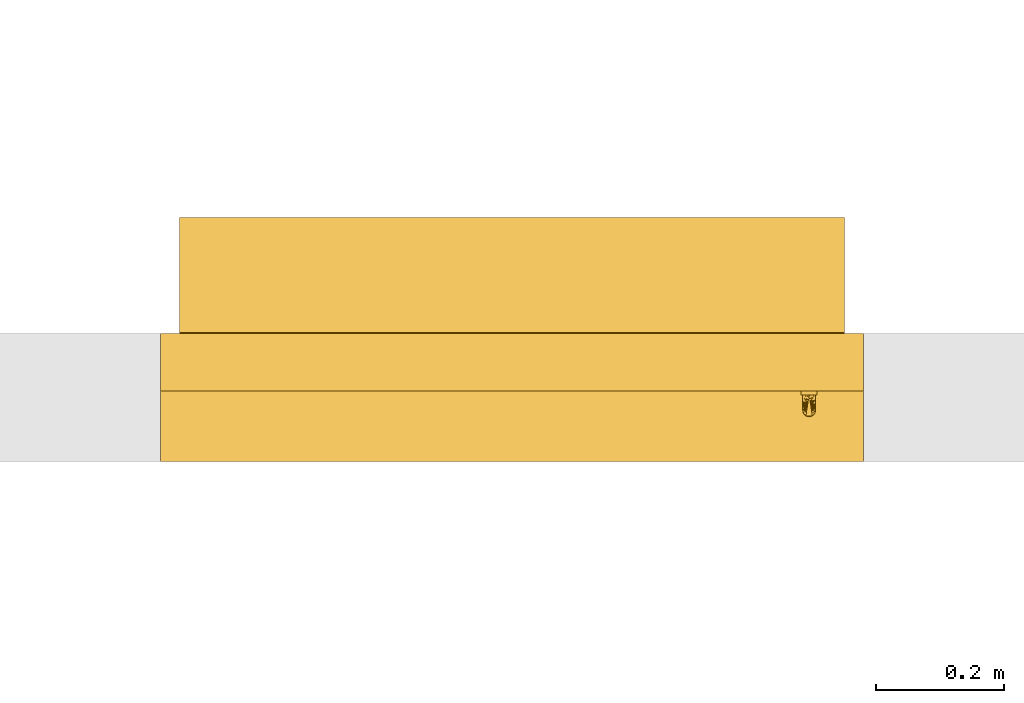
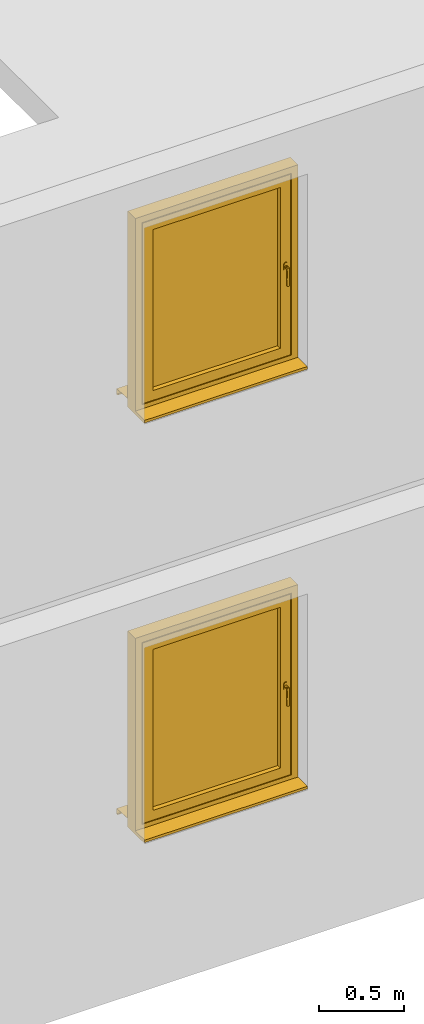
# Not in any storey, part 3 of 3: 2 windows.
"""IFC4 model written with IfcOpenShell, lengths in metres."""

from ifc_helpers import new_model, entity, si_unit, converted_unit, derived_unit, direction, frame, origin, place, context, subcontext, project, spatial, polygons, source, transform, mapped, material, constituent, constituent_set, type_object, type_shapes, element, save


model = new_model("IFC4")

# Units and contexts
model_context = context("Model", 3, precision=1e-05, world=origin(), true_north=direction((6.123031769111886e-17, 1.0)))
body_context = subcontext(model_context, "Body", "Model", "MODEL_VIEW")
ifc_project = project(units=[si_unit("LENGTHUNIT", "METRE"), si_unit("AREAUNIT", "SQUARE_METRE"), si_unit("VOLUMEUNIT", "CUBIC_METRE"), converted_unit("PLANEANGLEUNIT", "DEGREE", entity("IfcRatioMeasure", 0.017453292519943278), si_unit("PLANEANGLEUNIT", "RADIAN"), dimensions=[0, 0, 0, 0, 0, 0, 0]), si_unit("MASSUNIT", "GRAM", prefix="KILO"), derived_unit("MASSDENSITYUNIT", [(si_unit("MASSUNIT", "GRAM", prefix="KILO"), 1), (si_unit("LENGTHUNIT", "METRE"), -3)]), derived_unit("IONCONCENTRATIONUNIT", [(si_unit("MASSUNIT", "GRAM", prefix="KILO"), 1), (si_unit("LENGTHUNIT", "METRE"), -3)]), derived_unit("MOMENTOFINERTIAUNIT", [(si_unit("LENGTHUNIT", "METRE"), 4)]), si_unit("TIMEUNIT", "SECOND"), si_unit("FREQUENCYUNIT", "HERTZ"), si_unit("THERMODYNAMICTEMPERATUREUNIT", "DEGREE_CELSIUS"), derived_unit("THERMALTRANSMITTANCEUNIT", [(si_unit("MASSUNIT", "GRAM", prefix="KILO"), 1), (si_unit("THERMODYNAMICTEMPERATUREUNIT", "KELVIN"), -1), (si_unit("TIMEUNIT", "SECOND"), -3)]), derived_unit("THERMALCONDUCTANCEUNIT", [(si_unit("MASSUNIT", "GRAM", prefix="KILO"), 1), (si_unit("THERMODYNAMICTEMPERATUREUNIT", "KELVIN"), -1), (si_unit("TIMEUNIT", "SECOND"), -3), (si_unit("LENGTHUNIT", "METRE"), 1)]), derived_unit("VOLUMETRICFLOWRATEUNIT", [(si_unit("LENGTHUNIT", "METRE"), 3), (si_unit("TIMEUNIT", "SECOND"), -1)]), derived_unit("MASSFLOWRATEUNIT", [(si_unit("MASSUNIT", "GRAM", prefix="KILO"), 1), (si_unit("TIMEUNIT", "SECOND"), -1)]), derived_unit("ROTATIONALFREQUENCYUNIT", [(si_unit("TIMEUNIT", "SECOND"), -1)]), si_unit("ELECTRICCURRENTUNIT", "AMPERE"), si_unit("ELECTRICVOLTAGEUNIT", "VOLT"), si_unit("POWERUNIT", "WATT"), si_unit("FORCEUNIT", "NEWTON", prefix="KILO"), si_unit("ILLUMINANCEUNIT", "LUX"), si_unit("LUMINOUSFLUXUNIT", "LUMEN"), si_unit("LUMINOUSINTENSITYUNIT", "CANDELA"), derived_unit("USERDEFINED", [(si_unit("MASSUNIT", "GRAM", prefix="KILO"), -1), (si_unit("LENGTHUNIT", "METRE"), -2), (si_unit("TIMEUNIT", "SECOND"), 3), (si_unit("LUMINOUSFLUXUNIT", "LUMEN"), 1)]), derived_unit("USERDEFINED", [(si_unit("MASSUNIT", "GRAM", prefix="KILO"), 1), (si_unit("TIMEUNIT", "SECOND"), -3), (si_unit("LENGTHUNIT", "METRE"), 3), (si_unit("ELECTRICCURRENTUNIT", "AMPERE"), -2)]), derived_unit("SOUNDPOWERUNIT", [(si_unit("MASSUNIT", "GRAM", prefix="KILO"), 1), (si_unit("TIMEUNIT", "SECOND"), -3), (si_unit("LENGTHUNIT", "METRE"), 2)]), derived_unit("SOUNDPRESSUREUNIT", [(si_unit("MASSUNIT", "GRAM", prefix="KILO"), 1), (si_unit("LENGTHUNIT", "METRE"), -1), (si_unit("TIMEUNIT", "SECOND"), -2)]), derived_unit("LINEARVELOCITYUNIT", [(si_unit("LENGTHUNIT", "METRE"), 1), (si_unit("TIMEUNIT", "SECOND"), -1)]), si_unit("PRESSUREUNIT", "PASCAL"), derived_unit("USERDEFINED", [(si_unit("MASSUNIT", "GRAM", prefix="KILO"), 1), (si_unit("LENGTHUNIT", "METRE"), -2), (si_unit("TIMEUNIT", "SECOND"), -2)]), derived_unit("LINEARFORCEUNIT", [(si_unit("MASSUNIT", "GRAM", prefix="KILO"), 1), (si_unit("TIMEUNIT", "SECOND"), -2)]), derived_unit("PLANARFORCEUNIT", [(si_unit("MASSUNIT", "GRAM", prefix="KILO"), 1), (si_unit("LENGTHUNIT", "METRE"), -1), (si_unit("TIMEUNIT", "SECOND"), -2)]), derived_unit("SPECIFICHEATCAPACITYUNIT", [(si_unit("THERMODYNAMICTEMPERATUREUNIT", "KELVIN"), -1), (si_unit("LENGTHUNIT", "METRE"), 2), (si_unit("TIMEUNIT", "SECOND"), -2)]), derived_unit("HEATINGVALUEUNIT", [(si_unit("LENGTHUNIT", "METRE"), 2), (si_unit("TIMEUNIT", "SECOND"), -2)]), derived_unit("VAPORPERMEABILITYUNIT", [(si_unit("LENGTHUNIT", "METRE"), -1), (si_unit("TIMEUNIT", "SECOND"), 1)]), derived_unit("DYNAMICVISCOSITYUNIT", [(si_unit("MASSUNIT", "GRAM", prefix="KILO"), 1), (si_unit("TIMEUNIT", "SECOND"), -1), (si_unit("LENGTHUNIT", "METRE"), -1)]), derived_unit("THERMALEXPANSIONCOEFFICIENTUNIT", [(si_unit("THERMODYNAMICTEMPERATUREUNIT", "KELVIN"), -1)]), derived_unit("MODULUSOFELASTICITYUNIT", [(si_unit("MASSUNIT", "GRAM", prefix="KILO"), 1), (si_unit("LENGTHUNIT", "METRE"), -1), (si_unit("TIMEUNIT", "SECOND"), -2)]), derived_unit("ISOTHERMALMOISTURECAPACITYUNIT", [(si_unit("LENGTHUNIT", "METRE"), 3), (si_unit("MASSUNIT", "GRAM", prefix="KILO"), -1)]), derived_unit("MOISTUREDIFFUSIVITYUNIT", [(si_unit("TIMEUNIT", "SECOND"), -1), (si_unit("LENGTHUNIT", "METRE"), 2)])], contexts=[model_context])

# Site
site_placement = place(None, origin())
site = spatial("IfcSite", under=ifc_project, at=site_placement, CompositionType="ELEMENT")

# Windows
ifc_material_1 = material(Category="Metall")
ifc_constituent_1 = constituent(ifc_material_1, Category="Metall")
ifc_material_2 = material(Name="Kunststoff - grau 70-70-70", Category="Kunststoff")
ifc_constituent_2 = constituent(ifc_material_2, Name="Kunststoff - grau 70-70-70", Category="Kunststoff")
ifc_material_3 = material(Name="Glas - Isolierverglasung klar", Category="Glas")
ifc_constituent_3 = constituent(ifc_material_3, Name="Glas - Isolierverglasung klar", Category="Glas")
ifc_material_4 = material(Category="Holz")
ifc_constituent_4 = constituent(ifc_material_4, Category="Holz")
ifc_constituent_set_1 = constituent_set(constituents=[ifc_constituent_1, ifc_constituent_2, ifc_constituent_3, ifc_constituent_4])
ifc_constituent_5 = constituent(ifc_material_1, Category="Metall")
ifc_constituent_6 = constituent(ifc_material_2, Category="Kunststoff")
ifc_constituent_7 = constituent(ifc_material_3, Name="Glas", Category="Glas")
ifc_constituent_8 = constituent(ifc_material_2, Name="Fensterbank Aussen Blech", Category="Kunststoff")
ifc_constituent_9 = constituent(ifc_material_2, Name="Rahmen/Pfosten", Category="Kunststoff")
ifc_constituent_10 = constituent(ifc_material_4, Name="Fensterbank Innen", Category="Holz")
ifc_constituent_set_2 = constituent_set(constituents=[ifc_constituent_5, ifc_constituent_6, ifc_constituent_7, ifc_constituent_8, ifc_constituent_9, ifc_constituent_10])
window_type = type_object("IfcWindowType", Name="FE 1 tlg - DrehKipp:1100 x 1400", PartitioningType="NOTDEFINED", PredefinedType="WINDOW", material=ifc_constituent_set_2)
shared_shape = source(origin(), body_context, "Body", "Tessellation", [
    polygons([(1.0025000000000115, -0.24999999999999822, 0.7224999999999925), (1.0029259271713982, -0.2499999999999982, 0.7257352380637738), (1.0041746824527058, -0.2499999999999982, 0.7287499999999925), (1.0061611652351796, -0.2499999999999982, 0.7313388347648244), (1.0087500000000114, -0.2499999999999982, 0.7333253175472978), (1.0117647619362298, -0.2499999999999982, 0.7345740728286058), (1.0150000000000112, -0.2499999999999982, 0.7349999999999923), (1.018235238063793, -0.2499999999999982, 0.7345740728286058), (1.0212500000000113, -0.2499999999999982, 0.7333253175472978), (1.0238388347648433, -0.2499999999999982, 0.7313388347648244), (1.0258253175473169, -0.2499999999999982, 0.7287499999999925), (1.0270740728286247, -0.2499999999999982, 0.7257352380637738), (1.0275000000000114, -0.24999999999999822, 0.7224999999999925), (1.0275000000000112, -0.24999999999999825, 0.7049999999999924), (1.0275000000000112, -0.24999999999999833, 0.6874999999999923), (1.0270740728286245, -0.24999999999999833, 0.684264761936211), (1.0258253175473167, -0.24999999999999836, 0.6812499999999924), (1.023838834764843, -0.24999999999999836, 0.6786611652351604), (1.0212500000000113, -0.24999999999999836, 0.676674682452687), (1.0182352380637927, -0.24999999999999836, 0.6754259271713792), (1.0150000000000112, -0.24999999999999836, 0.6749999999999925), (1.0117647619362298, -0.24999999999999836, 0.6754259271713792), (1.0087500000000111, -0.24999999999999836, 0.676674682452687), (1.0061611652351794, -0.24999999999999836, 0.6786611652351604), (1.0041746824527058, -0.24999999999999836, 0.6812499999999924), (1.0029259271713977, -0.24999999999999833, 0.6842647619362108), (1.002500000000011, -0.24999999999999833, 0.6874999999999923), (1.0025000000000115, -0.24999999999999825, 0.7049999999999924), (1.0250000000000112, -0.27999999999999825, 0.7049999999999924), (1.0250000000000112, -0.2559999999999983, 0.7049999999999924), (1.024659258262902, -0.2559999999999983, 0.7075881904510176), (1.0236602540378559, -0.25599999999999823, 0.7099999999999924), (1.022071067811877, -0.25599999999999823, 0.7120710678118578), (1.0200000000000116, -0.25599999999999823, 0.7136602540378366), (1.0175881904510367, -0.25599999999999823, 0.714659258262883), (1.0150000000000114, -0.25599999999999823, 0.7149999999999923), (1.0124118095489862, -0.25599999999999823, 0.7146592582628832), (1.0100000000000116, -0.25599999999999823, 0.713660254037837), (1.007928932188146, -0.25599999999999823, 0.7120710678118581), (1.006339745962167, -0.25599999999999823, 0.7099999999999926), (1.0053407417371207, -0.2559999999999983, 0.7075881904510178), (1.0050000000000112, -0.2559999999999983, 0.7049999999999924), (1.0050000000000112, -0.2799999999999984, 0.7049999999999927), (1.0053407417371207, -0.2825881904510236, 0.7075881904510178), (1.006339745962167, -0.28499999999999837, 0.7099999999999926), (1.007928932188146, -0.2870710678118638, 0.7120710678118581), (1.0100000000000116, -0.2886602540378427, 0.713660254037837), (1.0124118095489862, -0.28965925826288896, 0.7146592582628832), (1.0150000000000114, -0.28999999999999826, 0.7149999999999925), (1.0175881904510367, -0.2896592582628889, 0.7146592582628832), (1.0200000000000116, -0.28866025403784257, 0.713660254037837), (1.022071067811877, -0.28707106781186364, 0.7120710678118578), (1.0236602540378559, -0.28499999999999814, 0.7099999999999924), (1.024659258262902, -0.28258819045102335, 0.7075881904510176), (1.0053407417371205, -0.2559999999999983, 0.7024118095489673), (1.0063397459621668, -0.2559999999999983, 0.6999999999999925), (1.007928932188146, -0.25599999999999834, 0.697928932188127), (1.0100000000000113, -0.25599999999999834, 0.6963397459621479), (1.012411809548986, -0.25599999999999834, 0.6953407417371018), (1.0150000000000112, -0.25599999999999834, 0.6949999999999925), (1.0175881904510364, -0.25599999999999834, 0.6953407417371018), (1.0200000000000113, -0.25599999999999834, 0.6963397459621482), (1.0220710678118767, -0.25599999999999834, 0.697928932188127), (1.0236602540378557, -0.2559999999999983, 0.6999999999999925), (1.024659258262902, -0.2559999999999983, 0.7024118095489673), (1.024659258262902, -0.27741180954897304, 0.7024118095489673), (1.0236602540378557, -0.27499999999999825, 0.6999999999999925), (1.0220710678118767, -0.2729289321881328, 0.697928932188127), (1.0200000000000113, -0.2713397459621539, 0.6963397459621482), (1.0175881904510364, -0.2703407417371076, 0.6953407417371018), (1.0150000000000112, -0.2699999999999983, 0.6949999999999925), (1.012411809548986, -0.2703407417371076, 0.6953407417371018), (1.0100000000000113, -0.27133974596215393, 0.6963397459621482), (1.007928932188146, -0.27292893218813286, 0.697928932188127), (1.0063397459621668, -0.2749999999999983, 0.6999999999999925), (1.0053407417371205, -0.2774118095489731, 0.7024118095489673), (1.0050000000000112, -0.26828435036563536, 0.7049999999999924), (1.0250000000000112, -0.2682843499334001, 0.7049999999999924), (1.0050000000000112, -0.2741421751828168, 0.7049999999999924), (1.0250000000000112, -0.2741421749666992, 0.7049999999999924), (1.0050000000000112, -0.2770710875914076, 0.7049999999999924), (1.0250000000000112, -0.27707108758376875, 0.7049999999999924), (1.025000000000011, -0.27999999999999864, 0.5849999999999926), (1.0246592582629015, -0.2825881904510238, 0.5849999999999926), (1.0236602540378552, -0.2849999999999986, 0.5849999999999926), (1.0220710678118765, -0.2870710678118641, 0.5849999999999926), (1.020000000000011, -0.288660254037843, 0.5849999999999926), (1.0175881904510362, -0.2896592582628893, 0.5849999999999926), (1.015000000000011, -0.2899999999999987, 0.5849999999999926), (1.0124118095489858, -0.2896592582628894, 0.5849999999999926), (1.0100000000000111, -0.2886602540378431, 0.5849999999999926), (1.0079289321881455, -0.2870710678118642, 0.5849999999999926), (1.0063397459621666, -0.28499999999999875, 0.5849999999999926), (1.0053407417371203, -0.28258819045102396, 0.5849999999999926), (1.0050000000000108, -0.2799999999999987, 0.5849999999999926), (1.0053407417371203, -0.27741180954897343, 0.5849999999999926), (1.0063397459621666, -0.2749999999999987, 0.5849999999999926), (1.0079289321881453, -0.2729289321881332, 0.5849999999999926), (1.010000000000011, -0.2713397459621543, 0.5849999999999926), (1.0124118095489856, -0.270340741737108, 0.5849999999999926), (1.0150000000000108, -0.26999999999999863, 0.5849999999999926), (1.017588190451036, -0.270340741737108, 0.5849999999999926), (1.020000000000011, -0.27133974596215427, 0.5849999999999926), (1.0220710678118765, -0.2729289321881332, 0.5849999999999926), (1.0236602540378552, -0.27499999999999863, 0.5849999999999926), (1.0246592582629015, -0.27741180954897343, 0.5849999999999926), (1.0250000000000112, -0.2799999999999984, 0.6497913024086116), (1.0050000000000112, -0.2799999999999985, 0.649791302728071), (1.0250000000000112, -0.27999999999999836, 0.6773956507457195), (1.0050000000000112, -0.27999999999999836, 0.6773956513640317), (1.0025000000000115, -0.25599999999999823, 0.7224999999999928), (1.0025000000000115, -0.2559999999999983, 0.7049999999999927), (1.002500000000011, -0.25599999999999834, 0.6874999999999926), (1.0029259271713977, -0.25599999999999834, 0.6842647619362113), (1.0041746824527058, -0.25599999999999834, 0.6812499999999927), (1.0061611652351794, -0.25599999999999834, 0.678661165235161), (1.0087500000000111, -0.25599999999999834, 0.6766746824526872), (1.0117647619362298, -0.2559999999999984, 0.6754259271713794), (1.0150000000000112, -0.2559999999999984, 0.6749999999999927), (1.0182352380637927, -0.2559999999999984, 0.6754259271713794), (1.0212500000000113, -0.25599999999999834, 0.6766746824526872), (1.023838834764843, -0.25599999999999834, 0.678661165235161), (1.0258253175473167, -0.25599999999999834, 0.6812499999999927), (1.0270740728286245, -0.25599999999999834, 0.6842647619362113), (1.0275000000000112, -0.25599999999999834, 0.6874999999999926), (1.0275000000000112, -0.2559999999999983, 0.7049999999999927), (1.0275000000000114, -0.25599999999999823, 0.7224999999999928), (1.0270740728286247, -0.25599999999999823, 0.7257352380637744), (1.0258253175473169, -0.2559999999999982, 0.7287499999999927), (1.0238388347648433, -0.2559999999999982, 0.7313388347648246), (1.0212500000000113, -0.2559999999999982, 0.7333253175472983), (1.018235238063793, -0.2559999999999982, 0.734574072828606), (1.0150000000000112, -0.2559999999999982, 0.7349999999999927), (1.0117647619362298, -0.2559999999999982, 0.734574072828606), (1.0087500000000114, -0.2559999999999982, 0.7333253175472983), (1.0061611652351796, -0.2559999999999982, 0.7313388347648246), (1.0041746824527058, -0.2559999999999982, 0.7287499999999927), (1.0029259271713982, -0.25599999999999823, 0.7257352380637744)], [[[16, 17, 18, 19, 20, 21, 22, 23, 24, 25, 26, 27, 28, 1, 2, 3, 4, 5, 6, 7, 8, 9, 10, 11, 12, 13, 14, 15]], [[54, 34, 53]], [[53, 35, 52]], [[50, 51, 47, 48, 49]], [[36, 52, 35]], [[51, 52, 36]], [[31, 29, 82, 80, 78, 30]], [[12, 128, 127, 13]], [[32, 29, 31]], [[29, 32, 33]], [[34, 54, 33]], [[33, 54, 29]], [[34, 35, 53]], [[36, 47, 51]], [[47, 36, 46]], [[44, 45, 38]], [[37, 45, 46]], [[43, 44, 39]], [[46, 36, 37]], [[45, 37, 38]], [[43, 39, 40]], [[41, 42, 77, 79, 81, 43]], [[1, 111, 138, 2]], [[41, 43, 40]], [[39, 44, 38]], [[75, 77, 74]], [[81, 79, 76, 43]], [[42, 55, 77]], [[26, 114, 113, 27]], [[67, 78, 80]], [[82, 29, 66, 80]], [[30, 78, 65]], [[15, 125, 124, 16]], [[57, 72, 73]], [[57, 73, 77]], [[73, 74, 77]], [[55, 56, 77]], [[57, 58, 72]], [[57, 77, 56]], [[59, 72, 58]], [[22, 118, 117, 23]], [[59, 60, 71, 72]], [[21, 119, 118, 22]], [[69, 78, 68]], [[63, 69, 70]], [[66, 67, 80]], [[68, 78, 67]], [[61, 70, 71, 60]], [[20, 120, 119, 21]], [[70, 61, 62]], [[20, 19, 121, 120]], [[76, 79, 75]], [[78, 69, 63]], [[75, 79, 77]], [[64, 65, 78]], [[63, 64, 78]], [[63, 70, 62]], [[105, 106, 83, 84, 85, 86, 87, 88, 89, 90, 91, 92, 93, 94, 95, 96, 97, 98, 99, 100, 101, 102, 103, 104]], [[84, 83, 107, 109, 29]], [[84, 29, 85]], [[51, 50, 88, 87]], [[86, 85, 54]], [[87, 86, 52, 51]], [[54, 53, 86]], [[85, 29, 54]], [[86, 53, 52]], [[50, 49, 89, 88]], [[46, 92, 91, 47]], [[47, 91, 90, 48]], [[94, 43, 110, 108, 95]], [[43, 94, 93]], [[44, 93, 92]], [[89, 49, 48, 90]], [[46, 45, 92]], [[45, 44, 92]], [[44, 43, 93]], [[98, 97, 108]], [[96, 108, 97]], [[108, 72, 100]], [[100, 99, 108]], [[99, 98, 108]], [[95, 108, 96]], [[110, 43, 76]], [[110, 76, 75]], [[101, 100, 72, 71]], [[72, 108, 73]], [[74, 73, 108]], [[75, 74, 110]], [[66, 109, 67]], [[110, 74, 108]], [[103, 107, 104]], [[102, 107, 103]], [[106, 107, 83]], [[109, 66, 29]], [[105, 107, 106]], [[104, 107, 105]], [[102, 101, 71, 70]], [[70, 107, 102]], [[69, 68, 107]], [[68, 109, 107]], [[107, 70, 69]], [[68, 67, 109]], [[116, 117, 118, 119, 120, 121, 122, 123, 124, 125, 126, 127, 128, 129, 130, 131, 132, 133, 134, 135, 136, 137, 138, 111, 112, 113, 114, 115], [60, 59, 58, 57, 56, 55, 42, 41, 40, 39, 38, 37, 36, 35, 34, 33, 32, 31, 30, 65, 64, 63, 62, 61]], [[2, 138, 137, 3]], [[5, 4, 136, 135]], [[136, 4, 3, 137]], [[6, 5, 135, 134]], [[6, 134, 133, 7]], [[7, 133, 132, 8]], [[8, 132, 131, 9]], [[11, 10, 130, 129]], [[130, 10, 9, 131]], [[12, 11, 129, 128]], [[14, 13, 127, 126, 125, 15]], [[16, 124, 123, 17]], [[19, 18, 122, 121]], [[122, 18, 17, 123]], [[25, 24, 116, 115]], [[116, 24, 23, 117]], [[26, 25, 115, 114]], [[28, 27, 113, 112, 111, 1]]], closed=True),
    polygons([(0.1200000000000046, -0.249999999999998, 1.2799999999999934), (0.12000000000000081, -0.25000000000000044, 0.12999999999999426), (0.12000000000000129, -0.15999999999999798, 0.1299999999999944), (0.120000000000005, -0.15999999999999798, 1.279999999999993), (0.9800000000000005, -0.15999999999999798, 0.12999999999999198), (0.9800000000000042, -0.15999999999999798, 1.2799999999999903), (0.09000000000000113, -0.16000000000000048, 0.09999999999999473), (0.09000000000000512, -0.15999999999999787, 1.3099999999999932), (1.0100000000000042, -0.15999999999999787, 1.3099999999999905), (1.0100000000000005, -0.16000000000000048, 0.09999999999999175), (0.9800000000000009, -0.25000000000000044, 0.12999999999999157), (0.9800000000000045, -0.249999999999998, 1.279999999999991), (0.05000000000000494, -0.24999999999999772, 1.3499999999999936), (0.05000000000000068, -0.24999999999999772, 0.05999999999999448), (1.0500000000000007, -0.24999999999999772, 0.059999999999991234), (1.050000000000005, -0.24999999999999772, 1.3499999999999903), (0.05000000000000494, -0.23499999999999802, 1.3499999999999936), (0.050000000000000745, -0.2350000000000008, 0.05999999999999448), (1.0500000000000007, -0.2350000000000008, 0.059999999999991234), (1.050000000000005, -0.23499999999999802, 1.3499999999999903), (0.06500000000000465, -0.23499999999999807, 1.3349999999999937), (0.06500000000000072, -0.23499999999999807, 0.07499999999999432), (1.0350000000000008, -0.23499999999999807, 0.07499999999999148), (1.0350000000000048, -0.23499999999999807, 1.3349999999999904), (0.06500000000000485, -0.20499999999999746, 1.3349999999999935), (0.06500000000000086, -0.2050000000000002, 0.07499999999999432), (1.0350000000000006, -0.2050000000000002, 0.07499999999999148), (1.0350000000000046, -0.20499999999999746, 1.3349999999999902), (0.07500000000000508, -0.20499999999999752, 1.324999999999993), (0.07500000000000116, -0.20499999999999752, 0.08499999999999489), (1.0250000000000004, -0.20499999999999752, 0.08499999999999192), (1.0250000000000044, -0.20499999999999752, 1.3249999999999897), (0.07500000000000508, -0.17499999999999807, 1.324999999999993), (0.07500000000000122, -0.17500000000000077, 0.08499999999999476), (1.0250000000000004, -0.17500000000000077, 0.08499999999999164), (1.0250000000000044, -0.17499999999999807, 1.3249999999999897), (0.09000000000000492, -0.17499999999999813, 1.3099999999999932), (0.09000000000000107, -0.17499999999999813, 0.0999999999999946), (1.0100000000000005, -0.17499999999999813, 0.09999999999999175), (1.0100000000000044, -0.17499999999999813, 1.3099999999999905)], [[[1, 2, 3, 4]], [[7, 8, 9, 10], [4, 3, 5, 6]], [[2, 11, 5, 3]], [[13, 14, 15, 16], [2, 1, 12, 11]], [[17, 18, 14, 13]], [[18, 19, 15, 14]], [[18, 17, 20, 19], [21, 22, 23, 24]], [[25, 26, 22, 21]], [[26, 27, 23, 22]], [[26, 25, 28, 27], [29, 30, 31, 32]], [[33, 34, 30, 29]], [[34, 35, 31, 30]], [[34, 33, 36, 35], [37, 38, 39, 40]], [[8, 7, 38, 37]], [[7, 10, 39, 38]], [[11, 12, 6, 5]], [[19, 20, 16, 15]], [[27, 28, 24, 23]], [[35, 36, 32, 31]], [[10, 9, 40, 39]], [[12, 1, 4, 6]], [[20, 17, 13, 16]], [[28, 25, 21, 24]], [[36, 33, 29, 32]], [[9, 8, 37, 40]]], closed=True),
    polygons([(0.1199999999999958, -0.17499999999999616, 0.13000000000002945), (0.9800000000000086, -0.17499999999999616, 0.13000000000002676), (0.9800000000000086, -0.21899999999999523, 0.13000000000002676), (0.1199999999999958, -0.21899999999999523, 0.13000000000002945), (0.11999999999999945, -0.17499999999999616, 1.2800000000000038), (0.11999999999999945, -0.21899999999999523, 1.2800000000000038), (0.9800000000000125, -0.21899999999999523, 1.2800000000000011), (0.9800000000000125, -0.17499999999999616, 1.2800000000000011)], [[[1, 2, 3, 4]], [[5, 1, 4, 6]], [[6, 4, 3, 7]], [[7, 3, 2, 8]], [[8, 2, 1, 5]], [[5, 6, 7, 8]]], closed=True),
    polygons([(0.0300000000000011, 0.022000000000001022, 0.010625243427690247), (0.030000000000001168, 2.1657342585967855e-15, 0.012000243427689935), (0.029999999999998663, -0.15799999999999967, 0.02187524342768972), (1.0699999999999996, -0.15799999999999967, 0.02187524342768972), (1.0699999999999994, 2.1657342585967855e-15, 0.012000243427689935), (1.0699999999999994, 0.022000000000001022, 0.010625243427690247), (0.0300000000000011, 0.022000000000001022, -0.02937475657231), (1.0699999999999994, 0.022000000000001022, -0.02937475657231), (0.0300000000000011, 0.010000000000000907, -0.02937475657231), (1.0699999999999994, 0.010000000000000907, -0.02937475657231), (0.0300000000000011, 0.010000000000000907, -0.027374756572310047), (1.0699999999999994, 0.010000000000000907, -0.027374756572310047), (0.0300000000000011, 0.020000000000001072, -0.027374756572310047), (1.0699999999999994, 0.020000000000001072, -0.027374756572310047), (0.0300000000000011, 0.020000000000001072, 0.008750000000000176), (1.0699999999999994, 0.020000000000001072, 0.008750000000000176), (0.030000000000001168, 2.1995738563873603e-15, 0.010000000000000028), (1.0699999999999994, 2.1995738563873603e-15, 0.010000000000000028), (1.0699999999999998, -0.15999999999999917, 0.02000000000000019), (0.02999999999999873, -0.15999999999999917, 0.02000000000000019), (0.02999999999999873, -0.15999999999999912, 0.040000000000000514), (1.0699999999999998, -0.15999999999999912, 0.040000000000000514), (0.02999999999999873, -0.15799999999999967, 0.040000000000000514), (1.0699999999999998, -0.15799999999999967, 0.040000000000000514)], [[[1, 2, 3, 4, 5, 6]], [[7, 1, 6, 8]], [[9, 7, 8, 10]], [[11, 9, 10, 12]], [[13, 11, 12, 14]], [[15, 13, 14, 16]], [[17, 15, 16, 18, 19, 20]], [[21, 20, 19, 22]], [[23, 21, 22, 24]], [[3, 23, 24, 4]], [[17, 2, 1, 7, 9, 11, 13, 15]], [[18, 5, 4, 24, 22, 19]], [[2, 17, 20, 21, 23, 3]], [[5, 18, 16, 14, 12, 10, 8, 6]]], closed=True),
    polygons([(1.0999999999999974, -0.160000000000978, 0.0), (1.0999999999999974, -0.25000000000097783, 0.0), (-2.0303758674344865e-16, -0.25000000000097783, 0.0), (-2.0303758674344865e-16, -0.160000000000978, 0.0), (1.0999999999999974, -0.160000000000978, 1.3999999999999884), (1.0999999999999974, -0.25000000000097783, 1.3999999999999884), (1.0549999999999995, -0.25000000000065253, 1.355), (1.0549999999999995, -0.25000000000065253, 0.0550000000000036), (0.04499999999999992, -0.250000000000652, 0.0550000000000036), (0.04499999999999999, -0.250000000000652, 1.355), (-2.0303758674344865e-16, -0.25000000000097783, 1.3999999999999884), (-2.0303758674344865e-16, -0.160000000000978, 1.3999999999999884), (1.0149999999999997, -0.1600000000006526, 0.09500000000000344), (1.0149999999999997, -0.1600000000006526, 1.3150000000000002), (0.0850000000000001, -0.16000000000065212, 1.3150000000000002), (0.0850000000000001, -0.16000000000065212, 0.09500000000000344), (1.0149999999999997, -0.17500000000000204, 0.09500000000000344), (1.0149999999999997, -0.17500000000000204, 1.3150000000000002), (0.0850000000000001, -0.17500000000000054, 0.09500000000000344), (0.0850000000000001, -0.17500000000000054, 1.3150000000000002), (1.0549999999999995, -0.23500000000000215, 1.355), (1.0549999999999997, -0.23500000000000215, 0.0550000000000036), (0.04499999999999992, -0.23500000000000051, 0.0550000000000036), (0.04499999999999992, -0.23500000000000051, 1.355), (1.0399999999999996, -0.2350000000000021, 1.3400000000000003), (1.0399999999999996, -0.2350000000000021, 0.07000000000000345), (0.05999999999999983, -0.23500000000000054, 0.07000000000000345), (0.05999999999999983, -0.23500000000000054, 1.3400000000000003), (1.0399999999999996, -0.20500000000000151, 0.07000000000000371), (1.0399999999999996, -0.20500000000000151, 1.3400000000000003), (0.06000000000000003, -0.20499999999999996, 1.3400000000000003), (0.0600000000000001, -0.20499999999999996, 0.07000000000000357), (1.0299999999999996, -0.20500000000000151, 1.33), (1.0299999999999996, -0.20500000000000151, 0.08000000000000361), (0.07000000000000026, -0.20499999999999996, 0.08000000000000361), (0.0700000000000002, -0.20499999999999996, 1.33), (1.0299999999999996, -0.17500000000000204, 0.08000000000000361), (1.0299999999999996, -0.17500000000000204, 1.33), (0.07000000000000026, -0.17500000000000054, 1.33), (0.07000000000000026, -0.17500000000000054, 0.08000000000000361)], [[[1, 2, 3, 4]], [[5, 6, 2, 1]], [[6, 11, 3, 2], [7, 8, 9, 10]], [[11, 12, 4, 3]], [[12, 5, 1, 4], [13, 14, 15, 16]], [[13, 17, 18, 14]], [[19, 16, 15, 20]], [[17, 13, 16, 19]], [[21, 22, 8, 7]], [[8, 22, 23, 9]], [[9, 23, 24, 10]], [[22, 21, 24, 23], [25, 26, 27, 28]], [[29, 30, 31, 32], [33, 34, 35, 36]], [[30, 29, 26, 25]], [[26, 29, 32, 27]], [[37, 38, 39, 40], [18, 17, 19, 20]], [[38, 37, 34, 33]], [[34, 37, 40, 35]], [[27, 32, 31, 28]], [[35, 40, 39, 36]], [[5, 12, 11, 6]], [[21, 7, 10, 24]], [[30, 25, 28, 31]], [[38, 33, 36, 39]], [[14, 18, 20, 15]]], closed=True),
    polygons([(-6.767919558114955e-17, -0.24999999999999867, 0.024999999999999866), (-6.767919558114955e-17, -0.36000000000096394, 0.024999999999999866), (1.0999999999999976, -0.36000000000096394, 0.024999999999999866), (1.0999999999999976, -0.24999999999999867, 0.024999999999999866), (-6.767919558114955e-17, -0.24999999999999867, 0.0), (1.0999999999999976, -0.24999999999999867, 0.0), (1.0999999999999976, -0.35000000000096393, 0.0), (-6.767919558114955e-17, -0.35000000000096393, 0.0), (-6.767919558114955e-17, -0.35000000000096393, 0.007000000000000033), (-6.767919558114955e-17, -0.36000000000096394, 0.007000000000000033), (1.0999999999999976, -0.36000000000096394, 0.007000000000000033), (1.0999999999999974, -0.35000000000096393, 0.007000000000000033)], [[[1, 2, 3, 4]], [[5, 6, 7, 8]], [[2, 1, 5, 8, 9, 10]], [[3, 2, 10, 11]], [[4, 3, 11, 12, 7, 6]], [[1, 4, 6, 5]], [[9, 12, 11, 10]], [[12, 9, 8, 7]]], closed=True),
])
type_shapes(window_type, [shared_shape])
window_1_placement = place(site_placement, frame((14.588526378542783, 10.760203538914585, 0.85)))
element("IfcWindow", 1, at=window_1_placement, inside=site, type_object=window_type, material=ifc_constituent_set_1, Name="FE 1 tlg - DrehKipp:1100 x 1400", ObjectType="FE 1 tlg - DrehKipp:1100 x 1400", OverallHeight=2.2500000000000044, OverallWidth=1.1000000000000012, PartitioningType="NOTDEFINED", PredefinedType="WINDOW", context=body_context, shape_type="MappedRepresentation", body=[
    mapped(shared_shape, transform((0.0, 0.0, 0.0), scale=1.0)),
])
ifc_constituent_11 = constituent(ifc_material_1, Category="Metall")
ifc_constituent_12 = constituent(ifc_material_2, Name="Kunststoff - grau 70-70-70", Category="Kunststoff")
ifc_constituent_13 = constituent(ifc_material_3, Name="Glas - Isolierverglasung klar", Category="Glas")
ifc_constituent_14 = constituent(ifc_material_4, Category="Holz")
ifc_constituent_set_3 = constituent_set(constituents=[ifc_constituent_11, ifc_constituent_12, ifc_constituent_13, ifc_constituent_14])
window_2_placement = place(site_placement, frame((14.588526378542783, 10.760203538914585, 3.85)))
element("IfcWindow", 2, at=window_2_placement, inside=site, type_object=window_type, material=ifc_constituent_set_3, Name="FE 1 tlg - DrehKipp:1100 x 1400", ObjectType="FE 1 tlg - DrehKipp:1100 x 1400", OverallHeight=2.2500000000000044, OverallWidth=1.1000000000000012, PartitioningType="NOTDEFINED", PredefinedType="WINDOW", context=body_context, shape_type="MappedRepresentation", body=[
    mapped(shared_shape, transform((0.0, 0.0, 0.0), scale=1.0)),
])

save(model, "model.ifc")
